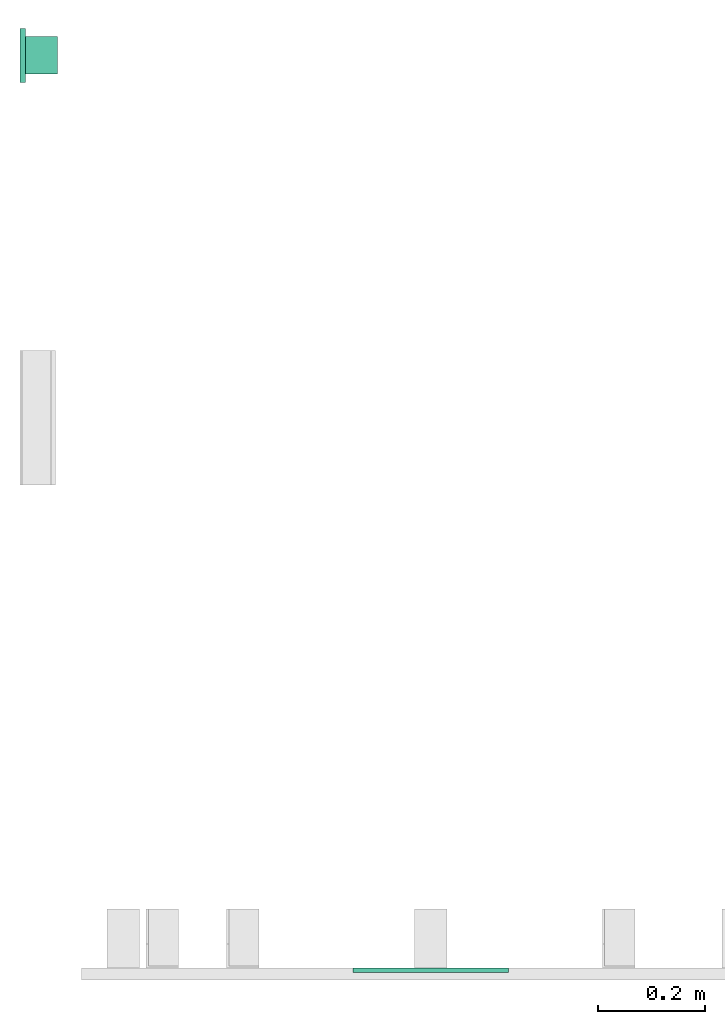
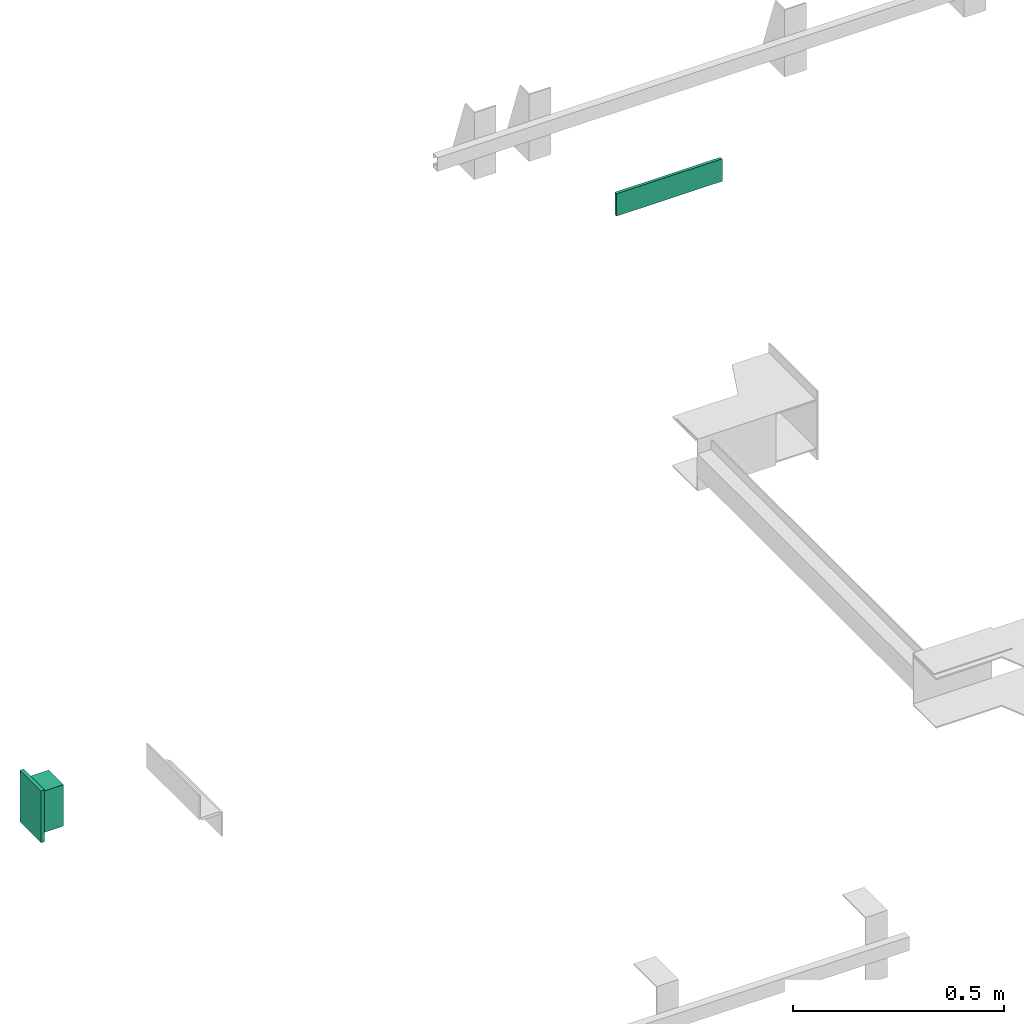
# One storey, part 3 of 4: 1 lamp, 1 switching device.
"""IFC4 building model written with IfcOpenShell, lengths in millimetres."""

from ifc_helpers import new_model, entity, si_unit, converted_unit, frame, origin_with_axes, place, context, subcontext, project, spatial, faceted_brep, element, save


model = new_model("IFC4")

# Units and contexts
context_of_model = context(None, 3, precision=0.01, world=origin_with_axes())
sub_context_1 = subcontext(context_of_model, None, None, "MODEL_VIEW")
sub_context_2 = subcontext(context_of_model, None, None, "MODEL_VIEW")
ifc_project = project(units=[converted_unit("PLANEANGLEUNIT", "degree", entity("IfcPlaneAngleMeasure", 0.017453292519943), si_unit("PLANEANGLEUNIT", "RADIAN"), dimensions=[0, 0, 0, 0, 0, 0, 0]), si_unit("LENGTHUNIT", "METRE", prefix="MILLI"), si_unit("MASSUNIT", "GRAM", prefix="KILO"), converted_unit("TIMEUNIT", "year", entity("IfcTimeMeasure", 31557600.0), si_unit("TIMEUNIT", "SECOND"), dimensions=[0, 0, 1, 0, 0, 0, 0]), si_unit("THERMODYNAMICTEMPERATUREUNIT", "DEGREE_CELSIUS"), si_unit("AREAUNIT", "SQUARE_METRE"), si_unit("FORCEUNIT", "NEWTON"), si_unit("VOLUMEUNIT", "CUBIC_METRE"), si_unit("PRESSUREUNIT", "PASCAL"), si_unit("SOLIDANGLEUNIT", "STERADIAN")], contexts=[context_of_model])

# Site, building, storey
site = spatial("IfcSite", under=ifc_project)
building = spatial("IfcBuilding", under=site, Name="Document")
placement = place(None, origin_with_axes())
storey_placement = place(placement, frame((0.0, 0.0, -20400.0), z_axis=(0.0, 0.0, 1.0), x_axis=(1.0, 0.0, 0.0)))
storey = spatial("IfcBuildingStorey", under=building, at=storey_placement, Name="P8", Elevation=-20400.0)

# Switching device
switching_device_placement = place(storey_placement, frame((765.0, 0.0, 2280.0), z_axis=(0.0, 0.0, 1.0), x_axis=(1.0, 0.0, 0.0)))
element("IfcSwitchingDevice", 1, at=switching_device_placement, inside=storey, context=sub_context_1, shape_type="Brep", body=[
    faceted_brep([(-145.0, -8.0, 32.5), (145.0, -8.0, 32.5), (145.0, 0.0, 32.5), (-145.0, 0.0, 32.5), (-145.0, -8.0, -32.5), (-145.0, 0.0, -32.5), (145.0, 0.0, -32.5), (145.0, -8.0, -32.5)], [[[0, 1, 2, 3]], [[4, 5, 6, 7]], [[0, 3, 5, 4]], [[3, 2, 6, 5]], [[2, 1, 7, 6]], [[1, 0, 4, 7]]]),
])

# Lamp
lamp_placement = place(storey_placement, frame((0.0, 1700.0, -281.5384615384619), z_axis=(0.0, 0.0, 1.0), x_axis=(0.0, -1.0, 0.0)))
element("IfcLamp", 2, at=lamp_placement, inside=storey, ObjectType="Lamp S5500", context=sub_context_2, shape_type="Brep", body=[
    faceted_brep([(50.0, 0.0, 74.99988731971189), (50.0, 10.0, 74.99988731971189), (-50.0, 10.0, 74.99988731971189), (-50.0, 0.0, 74.99988731971189), (50.0, 0.0, -75.00011268028811), (-50.0, 0.0, -75.00011268028811), (-50.0, 10.0, -75.00011268028811), (50.0, 10.0, -75.00011268028811)], [[[0, 1, 2, 3]], [[4, 5, 6, 7]], [[0, 3, 5, 4]], [[3, 2, 6, 5]], [[2, 1, 7, 6]], [[1, 0, 4, 7]]]),
    faceted_brep([(35.0, 10.0, 59.99988731971189), (35.0, 70.0, 59.99988731971189), (-35.0, 70.0, 59.99988731971189), (-35.0, 10.0, 59.99988731971189), (35.0, 10.0, -60.00011268028811), (-35.0, 10.0, -60.00011268028811), (-35.0, 70.0, -60.00011268028811), (35.0, 70.0, -60.00011268028811)], [[[0, 1, 2, 3]], [[4, 5, 6, 7]], [[0, 3, 5, 4]], [[3, 2, 6, 5]], [[2, 1, 7, 6]], [[1, 0, 4, 7]]]),
])

save(model, "model.ifc")
